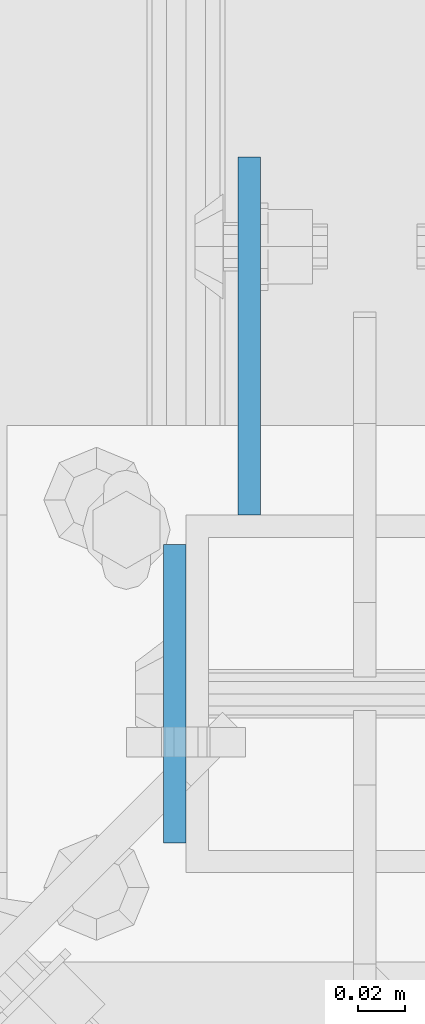
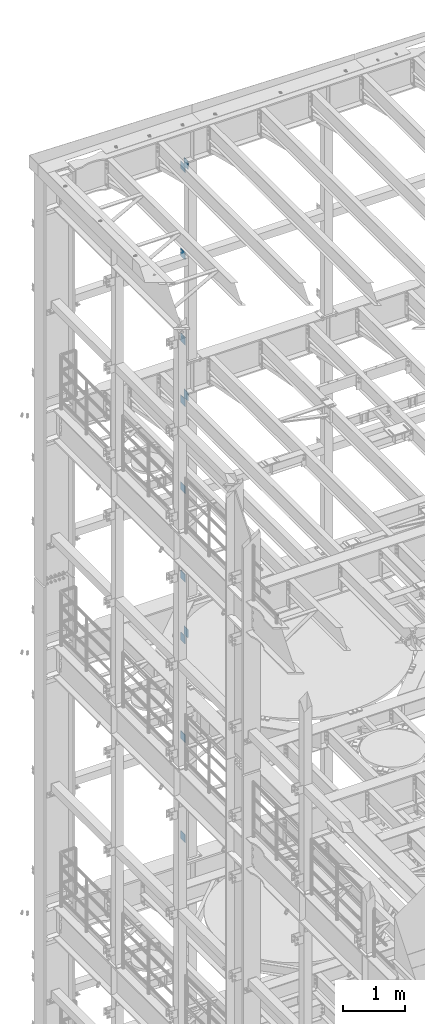
# One storey, part 1319 of 1876: 12 beams, 6 elements without a shape of their own.
"""IFC2X3 building model written with IfcOpenShell, lengths in millimetres."""

from ifc_helpers import new_model, si_unit, frame, origin_with_axes, place, context, subcontext, project, spatial, faceted_brep, material, type_object, element, aggregate, save


model = new_model("IFC2X3")

# Units and contexts
model_context = context("Model", 3, precision=1e-05, world=origin_with_axes())
body_context = subcontext(model_context, "Body", "Model", "MODEL_VIEW")
ifc_project = project(units=[si_unit("LENGTHUNIT", "METRE", prefix="MILLI"), si_unit("AREAUNIT", "SQUARE_METRE"), si_unit("VOLUMEUNIT", "CUBIC_METRE"), si_unit("MASSUNIT", "GRAM", prefix="KILO"), si_unit("TIMEUNIT", "SECOND"), si_unit("PLANEANGLEUNIT", "RADIAN"), si_unit("SOLIDANGLEUNIT", "STERADIAN"), si_unit("THERMODYNAMICTEMPERATUREUNIT", "DEGREE_CELSIUS"), si_unit("LUMINOUSINTENSITYUNIT", "LUMEN")], contexts=[model_context])

# Site, building, storey
site_placement = place(None, origin_with_axes())
site = spatial("IfcSite", under=ifc_project, at=site_placement, CompositionType="ELEMENT")
building_placement = place(site_placement, origin_with_axes())
building = spatial("IfcBuilding", under=site, at=building_placement, Name="Undefined", CompositionType="ELEMENT")
storey_placement = place(building_placement, origin_with_axes())
storey = spatial("IfcBuildingStorey", under=building, at=storey_placement, Name="Undefined", CompositionType="ELEMENT", Elevation=0.0)

# Assembly, beams
assembly_1_placement = place(storey_placement, origin_with_axes())
assembly_1 = element("IfcElementAssembly", 1, at=assembly_1_placement, inside=storey, Name="FRAME", AssemblyPlace="NOTDEFINED", PredefinedType="RIGID_FRAME")
ifc_material = material(Name="STEEL/A36")
beam_type_1 = type_object("IfcBeamType", PredefinedType="NOTDEFINED")
beam_1_placement = place(assembly_1_placement, frame((2490.7762944527, 13792.2, 21678.9), z_axis=(0.0, 0.0, -1.0), x_axis=(0.0, 1.0, 0.0)))
beam_1 = element("IfcBeam", 2, at=beam_1_placement, type_object=beam_type_1, material=ifc_material, Name="PLATE", context=body_context, shape_type="Brep", body=[
    faceted_brep([(0.0, 4.76249999999982, -76.1999999999998), (3.63797880709171e-12, 4.76249999999982, 76.1999969482422), (152.399993896484, 4.76250000000073, 76.1999969482422), (152.4, 4.76249999999982, -76.1999999999998), (3.63797880709171e-12, -4.76249999999982, 76.1999969482422), (152.399993896484, -4.76250000000073, 76.1999969482422), (0.0, -4.76249999999982, -76.1999999999998), (152.4, -4.76249999999982, -76.1999999999998)], [[[0, 1, 2, 3]], [[4, 5, 2, 1]], [[4, 6, 7, 5]], [[6, 0, 3, 7]], [[5, 7, 3, 2]], [[6, 4, 1, 0]]]),
])
beam_2_placement = place(assembly_1_placement, frame((2490.7762944527, 13792.2, 19958.05), z_axis=(0.0, 0.0, -1.0), x_axis=(0.0, 1.0, 0.0)))
beam_2 = element("IfcBeam", 3, at=beam_2_placement, type_object=beam_type_1, material=ifc_material, Name="PLATE", context=body_context, shape_type="Brep", body=[
    faceted_brep([(0.0, 4.76249999999982, -76.1999999999998), (3.63797880709171e-12, 4.76249999999982, 76.1999969482422), (152.399993896484, 4.76250000000073, 76.1999969482422), (152.4, 4.76249999999982, -76.1999999999998), (3.63797880709171e-12, -4.76249999999982, 76.1999969482422), (152.399993896484, -4.76250000000073, 76.1999969482422), (0.0, -4.76249999999982, -76.1999999999998), (152.4, -4.76249999999982, -76.1999999999998)], [[[0, 1, 2, 3]], [[4, 5, 2, 1]], [[4, 6, 7, 5]], [[6, 0, 3, 7]], [[5, 7, 3, 2]], [[6, 4, 1, 0]]]),
])
beam_3_placement = place(assembly_1_placement, frame((2490.7762944527, 13792.2, 18275.3), z_axis=(0.0, 0.0, -1.0), x_axis=(0.0, 1.0, 0.0)))
beam_3 = element("IfcBeam", 4, at=beam_3_placement, type_object=beam_type_1, material=ifc_material, Name="PLATE", context=body_context, shape_type="Brep", body=[
    faceted_brep([(0.0, 4.76249999999982, -76.1999999999998), (3.63797880709171e-12, 4.76249999999982, 76.1999969482422), (152.399993896484, 4.76250000000073, 76.1999969482422), (152.4, 4.76249999999982, -76.1999999999998), (3.63797880709171e-12, -4.76249999999982, 76.1999969482422), (152.399993896484, -4.76250000000073, 76.1999969482422), (0.0, -4.76249999999982, -76.1999999999998), (152.4, -4.76249999999982, -76.1999999999998)], [[[0, 1, 2, 3]], [[4, 5, 2, 1]], [[4, 6, 7, 5]], [[6, 0, 3, 7]], [[5, 7, 3, 2]], [[6, 4, 1, 0]]]),
])
aggregate(assembly_1, [beam_1, beam_2, beam_3])

assembly_2_placement = place(storey_placement, origin_with_axes())
assembly_2 = element("IfcElementAssembly", 5, at=assembly_2_placement, inside=storey, Name="FRAME", AssemblyPlace="NOTDEFINED", PredefinedType="RIGID_FRAME")
beam_4_placement = place(assembly_2_placement, frame((2490.7762944527, 13792.2, 17056.1), z_axis=(0.0, 0.0, -1.0), x_axis=(0.0, 1.0, 0.0)))
beam_4 = element("IfcBeam", 6, at=beam_4_placement, type_object=beam_type_1, material=ifc_material, Name="PLATE", context=body_context, shape_type="Brep", body=[
    faceted_brep([(0.0, 4.76249999999982, -76.1999999999998), (3.63797880709171e-12, 4.76249999999982, 76.1999969482422), (152.399993896484, 4.76250000000073, 76.1999969482422), (152.4, 4.76249999999982, -76.1999999999998), (3.63797880709171e-12, -4.76249999999982, 76.1999969482422), (152.399993896484, -4.76250000000073, 76.1999969482422), (0.0, -4.76249999999982, -76.1999999999998), (152.4, -4.76249999999982, -76.1999999999998)], [[[0, 1, 2, 3]], [[4, 5, 2, 1]], [[4, 6, 7, 5]], [[6, 0, 3, 7]], [[5, 7, 3, 2]], [[6, 4, 1, 0]]]),
])
beam_5_placement = place(assembly_2_placement, frame((2490.7762944527, 13792.2, 15335.25), z_axis=(0.0, 0.0, -1.0), x_axis=(0.0, 1.0, 0.0)))
beam_5 = element("IfcBeam", 7, at=beam_5_placement, type_object=beam_type_1, material=ifc_material, Name="PLATE", context=body_context, shape_type="Brep", body=[
    faceted_brep([(0.0, 4.76249999999982, -76.1999999999998), (3.63797880709171e-12, 4.76249999999982, 76.1999969482422), (152.399993896484, 4.76250000000073, 76.1999969482422), (152.4, 4.76249999999982, -76.1999999999998), (3.63797880709171e-12, -4.76249999999982, 76.1999969482422), (152.399993896484, -4.76250000000073, 76.1999969482422), (0.0, -4.76249999999982, -76.1999999999998), (152.4, -4.76249999999982, -76.1999999999998)], [[[0, 1, 2, 3]], [[4, 5, 2, 1]], [[4, 6, 7, 5]], [[6, 0, 3, 7]], [[5, 7, 3, 2]], [[6, 4, 1, 0]]]),
])
beam_6_placement = place(assembly_2_placement, frame((2490.7762944527, 13792.2, 13589.0), z_axis=(0.0, 0.0, -1.0), x_axis=(0.0, 1.0, 0.0)))
beam_6 = element("IfcBeam", 8, at=beam_6_placement, type_object=beam_type_1, material=ifc_material, Name="PLATE", context=body_context, shape_type="Brep", body=[
    faceted_brep([(0.0, 4.76249999999982, -76.1999999999998), (3.63797880709171e-12, 4.76249999999982, 76.1999969482422), (152.399993896484, 4.76250000000073, 76.1999969482422), (152.4, 4.76249999999982, -76.1999999999998), (3.63797880709171e-12, -4.76249999999982, 76.1999969482422), (152.399993896484, -4.76250000000073, 76.1999969482422), (0.0, -4.76249999999982, -76.1999999999998), (152.4, -4.76249999999982, -76.1999999999998)], [[[0, 1, 2, 3]], [[4, 5, 2, 1]], [[4, 6, 7, 5]], [[6, 0, 3, 7]], [[5, 7, 3, 2]], [[6, 4, 1, 0]]]),
])
aggregate(assembly_2, [beam_4, beam_5, beam_6])

assembly_3_placement = place(storey_placement, origin_with_axes())
assembly_3 = element("IfcElementAssembly", 9, at=assembly_3_placement, inside=storey, Name="FRAME", AssemblyPlace="NOTDEFINED", PredefinedType="RIGID_FRAME")
beam_7_placement = place(assembly_3_placement, frame((2490.7762944527, 13792.2, 12369.8), z_axis=(0.0, 0.0, -1.0), x_axis=(0.0, 1.0, 0.0)))
beam_7 = element("IfcBeam", 10, at=beam_7_placement, type_object=beam_type_1, material=ifc_material, Name="PLATE", context=body_context, shape_type="Brep", body=[
    faceted_brep([(0.0, 4.76249999999982, -76.1999999999998), (3.63797880709171e-12, 4.76249999999982, 76.1999969482422), (152.399993896484, 4.76250000000073, 76.1999969482422), (152.4, 4.76249999999982, -76.1999999999998), (3.63797880709171e-12, -4.76249999999982, 76.1999969482422), (152.399993896484, -4.76250000000073, 76.1999969482422), (0.0, -4.76249999999982, -76.1999999999998), (152.4, -4.76249999999982, -76.1999999999998)], [[[0, 1, 2, 3]], [[4, 5, 2, 1]], [[4, 6, 7, 5]], [[6, 0, 3, 7]], [[5, 7, 3, 2]], [[6, 4, 1, 0]]]),
])
beam_8_placement = place(assembly_3_placement, frame((2490.7762944527, 13792.2, 10420.35), z_axis=(0.0, 0.0, -1.0), x_axis=(0.0, 1.0, 0.0)))
beam_8 = element("IfcBeam", 11, at=beam_8_placement, type_object=beam_type_1, material=ifc_material, Name="PLATE", context=body_context, shape_type="Brep", body=[
    faceted_brep([(0.0, 4.76249999999982, -76.1999999999998), (3.63797880709171e-12, 4.76249999999982, 76.1999969482422), (152.399993896484, 4.76250000000073, 76.1999969482422), (152.4, 4.76249999999982, -76.1999999999998), (3.63797880709171e-12, -4.76249999999982, 76.1999969482422), (152.399993896484, -4.76250000000073, 76.1999969482422), (0.0, -4.76249999999982, -76.1999999999998), (152.4, -4.76249999999982, -76.1999999999998)], [[[0, 1, 2, 3]], [[4, 5, 2, 1]], [[4, 6, 7, 5]], [[6, 0, 3, 7]], [[5, 7, 3, 2]], [[6, 4, 1, 0]]]),
])
beam_9_placement = place(assembly_3_placement, frame((2490.7762944527, 13792.2, 8445.5), z_axis=(0.0, 0.0, -1.0), x_axis=(0.0, 1.0, 0.0)))
beam_9 = element("IfcBeam", 12, at=beam_9_placement, type_object=beam_type_1, material=ifc_material, Name="PLATE", context=body_context, shape_type="Brep", body=[
    faceted_brep([(0.0, 4.76249999999982, -76.1999999999998), (3.63797880709171e-12, 4.76249999999982, 76.1999969482422), (152.399993896484, 4.76250000000073, 76.1999969482422), (152.4, 4.76249999999982, -76.1999999999998), (3.63797880709171e-12, -4.76249999999982, 76.1999969482422), (152.399993896484, -4.76250000000073, 76.1999969482422), (0.0, -4.76249999999982, -76.1999999999998), (152.4, -4.76249999999982, -76.1999999999998)], [[[0, 1, 2, 3]], [[4, 5, 2, 1]], [[4, 6, 7, 5]], [[6, 0, 3, 7]], [[5, 7, 3, 2]], [[6, 4, 1, 0]]]),
])
aggregate(assembly_3, [beam_7, beam_8, beam_9])

# Assembly, beam
assembly_4_placement = place(storey_placement, origin_with_axes())
assembly_4 = element("IfcElementAssembly", 13, at=assembly_4_placement, inside=storey, Name="BEAM", AssemblyPlace="NOTDEFINED", PredefinedType="RIGID_FRAME")
beam_type_2 = type_object("IfcBeamType", PredefinedType="NOTDEFINED")
beam_10_placement = place(assembly_4_placement, frame((2459.0375, 13779.5, 12598.4), z_axis=(0.0, 0.0, -1.0), x_axis=(0.0, -1.0, 0.0)))
beam_10 = element("IfcBeam", 14, at=beam_10_placement, type_object=beam_type_2, material=ifc_material, Name="PLATE", context=body_context, shape_type="Brep", body=[
    faceted_brep([(0.0, 4.76249999999982, -82.5499999999993), (0.0, 4.76249999999982, 82.5499999999993), (127.0, 4.76249999999982, 82.5499999999993), (127.0, 4.76249999999982, -82.5499999999993), (0.0, -4.76249999999982, 82.5499999999993), (127.0, -4.76249999999982, 82.5499999999993), (0.0, -4.76249999999982, -82.5499999999993), (127.0, -4.76249999999982, -82.5499999999993)], [[[0, 1, 2, 3]], [[1, 4, 5, 2]], [[4, 6, 7, 5]], [[6, 0, 3, 7]], [[5, 7, 3, 2]], [[6, 4, 1, 0]]]),
])
aggregate(assembly_4, [beam_10])

assembly_5_placement = place(storey_placement, origin_with_axes())
assembly_5 = element("IfcElementAssembly", 15, at=assembly_5_placement, inside=storey, Name="BEAM", AssemblyPlace="NOTDEFINED", PredefinedType="RIGID_FRAME")
beam_11_placement = place(assembly_5_placement, frame((2459.0375, 13779.5, 17278.35), z_axis=(0.0, 0.0, -1.0), x_axis=(0.0, -1.0, 0.0)))
beam_11 = element("IfcBeam", 16, at=beam_11_placement, type_object=beam_type_2, material=ifc_material, Name="PLATE", context=body_context, shape_type="Brep", body=[
    faceted_brep([(0.0, 4.76249999999982, -82.5499999999993), (0.0, 4.76249999999982, 82.5499999999993), (127.0, 4.76249999999982, 82.5499999999993), (127.0, 4.76249999999982, -82.5499999999993), (0.0, -4.76249999999982, 82.5499999999993), (127.0, -4.76249999999982, 82.5499999999993), (0.0, -4.76249999999982, -82.5499999999993), (127.0, -4.76249999999982, -82.5499999999993)], [[[0, 1, 2, 3]], [[1, 4, 5, 2]], [[4, 6, 7, 5]], [[6, 0, 3, 7]], [[5, 7, 3, 2]], [[6, 4, 1, 0]]]),
])
aggregate(assembly_5, [beam_11])

assembly_6_placement = place(storey_placement, origin_with_axes())
assembly_6 = element("IfcElementAssembly", 17, at=assembly_6_placement, inside=storey, Name="BEAM", AssemblyPlace="NOTDEFINED", PredefinedType="RIGID_FRAME")
beam_12_placement = place(assembly_6_placement, frame((2459.0375, 13779.5, 21850.35), z_axis=(0.0, 0.0, -1.0), x_axis=(0.0, -1.0, 0.0)))
beam_12 = element("IfcBeam", 18, at=beam_12_placement, type_object=beam_type_2, material=ifc_material, Name="PLATE", context=body_context, shape_type="Brep", body=[
    faceted_brep([(0.0, 4.76249999999982, -82.5499999999993), (0.0, 4.76249999999982, 82.5499999999993), (127.0, 4.76249999999982, 82.5499999999993), (127.0, 4.76249999999982, -82.5499999999993), (0.0, -4.76249999999982, 82.5499999999993), (127.0, -4.76249999999982, 82.5499999999993), (0.0, -4.76249999999982, -82.5499999999993), (127.0, -4.76249999999982, -82.5499999999993)], [[[0, 1, 2, 3]], [[1, 4, 5, 2]], [[4, 6, 7, 5]], [[6, 0, 3, 7]], [[5, 7, 3, 2]], [[6, 4, 1, 0]]]),
])
aggregate(assembly_6, [beam_12])

save(model, "model.ifc")
